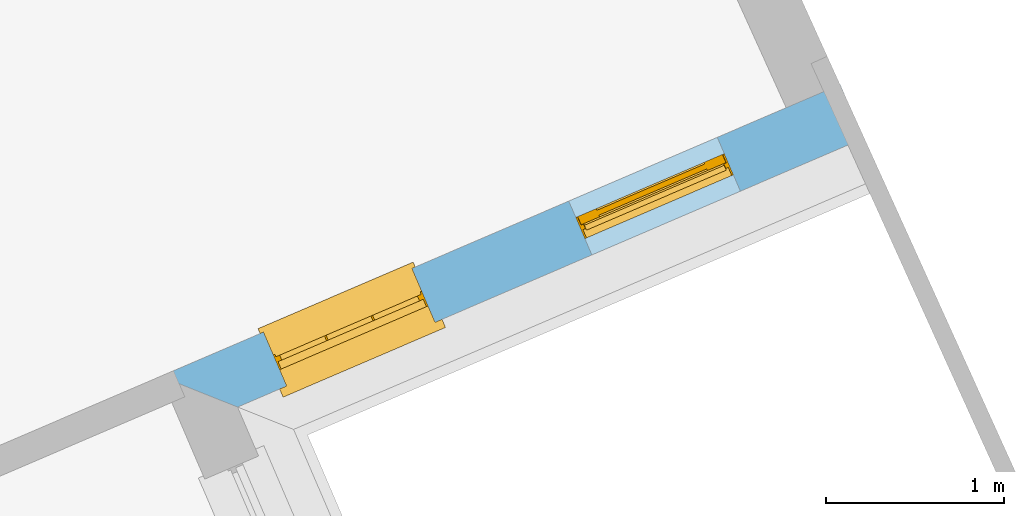
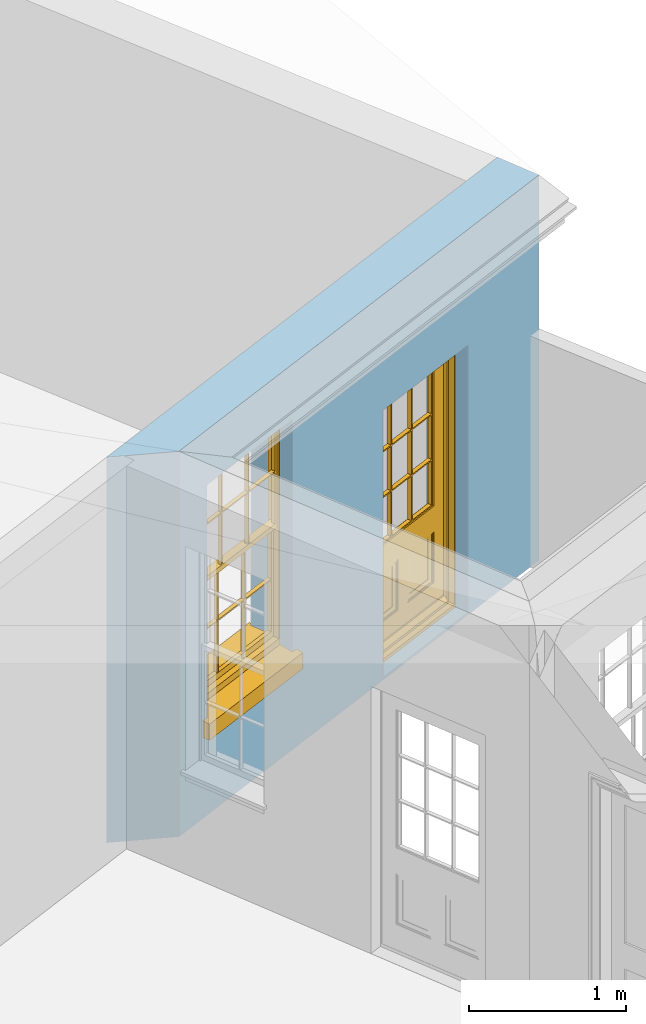
# One storey, part 13 of 19: 1 door, 1 window, 2 openings, plus 1 element that does not belong to this part.
"""IFC2X3 building model written with IfcOpenShell, lengths in metres."""

import ifcopenshell
import ifcopenshell.guid

model = None  # the IFC model being written
_history = None  # IfcOwnerHistory: only IFC2X3 demands one
_inside = {}  # id of a spatial element -> (the spatial element, [elements in it])
_under = {}  # id of a project, library or spatial element -> (it, [spatial elements below it])
_declared = {}  # id of a project -> (the project, [libraries it declares])
_typed = {}  # id of a type object -> (the type object, [elements of that type])
_made_of = {}  # id of a material, layer set ... -> (it, [elements and type objects made of it])


def new_model(schema):
    """Start an empty IFC model of exactly this schema.

    Asked for "IFC4X3", IfcOpenShell would pick the latest addendum, in which some entities
    have other attributes; the version numbers below select the first issue.
    IFC2X3 requires an IfcOwnerHistory on every rooted entity: one is made here for all.
    """
    global model, _history
    if schema == "IFC4X3":
        model = ifcopenshell.file(schema_version=(4, 3, 0, 0))
    else:
        model = ifcopenshell.file(schema=schema)
    _inside.clear()
    _under.clear()
    _declared.clear()
    _typed.clear()
    _made_of.clear()
    _history = None
    if model.schema == "IFC2X3":
        org = make("IfcOrganization", Name="unknown")
        user = make(
            "IfcPersonAndOrganization",
            ThePerson=make("IfcPerson", FamilyName="unknown"),
            TheOrganization=org,
        )
        app = make(
            "IfcApplication",
            ApplicationDeveloper=org,
            Version="unknown",
            ApplicationFullName="unknown",
            ApplicationIdentifier="unknown",
        )
        _history = make(
            "IfcOwnerHistory",
            OwningUser=user,
            OwningApplication=app,
            ChangeAction="ADDED",
            CreationDate=0,
        )
    return model


def make(cls, **values):
    """One entity of the class cls with the attributes given. An attribute that is None is left unset."""
    return model.create_entity(
        cls, **{name: value for name, value in values.items() if value is not None}
    )


def rooted(cls, **values):
    """An entity with a GlobalId (a new one), such as an element, a storey or a relation."""
    return make(cls, GlobalId=ifcopenshell.guid.new(), OwnerHistory=_history, **values)


def si_unit(unit_type, name, prefix=None):
    """IfcSIUnit, for example si_unit("LENGTHUNIT", "METRE", prefix="MILLI")."""
    return make("IfcSIUnit", UnitType=unit_type, Prefix=prefix, Name=name)


def assignment(units):
    """IfcUnitAssignment: the units of a project."""
    return None if units is None else make("IfcUnitAssignment", Units=units)


def point(xyz):
    """IfcCartesianPoint."""
    return None if xyz is None else make("IfcCartesianPoint", Coordinates=xyz)


def direction(xyz):
    """IfcDirection."""
    return None if xyz is None else make("IfcDirection", DirectionRatios=xyz)


def frame(location, z_axis=None, x_axis=None):
    """IfcAxis2Placement3D, a coordinate frame: its origin and axes. An axis left out is left unset."""
    return make(
        "IfcAxis2Placement3D",
        Location=point(location),
        Axis=direction(z_axis),
        RefDirection=direction(x_axis),
    )


def origin():
    """The frame at (0, 0, 0) with its axes left unset."""
    return frame((0.0, 0.0, 0.0))


def place(relative_to, where):
    """IfcLocalPlacement: puts the frame where relative to a parent placement (None: the world)."""
    return make(
        "IfcLocalPlacement", PlacementRelTo=relative_to, RelativePlacement=where
    )


def context(
    kind, dimensions, precision=None, world=None, true_north=None, identifier=None
):
    """IfcGeometricRepresentationContext, for example the 3D "Model" context."""
    return make(
        "IfcGeometricRepresentationContext",
        ContextIdentifier=identifier,
        ContextType=kind,
        CoordinateSpaceDimension=dimensions,
        Precision=precision,
        WorldCoordinateSystem=world,
        TrueNorth=true_north,
    )


def subcontext(parent, identifier, kind, view, scale=None):
    """IfcGeometricRepresentationSubContext, for example "Body" below "Model"."""
    return make(
        "IfcGeometricRepresentationSubContext",
        ContextIdentifier=identifier,
        ContextType=kind,
        ParentContext=parent,
        TargetScale=scale,
        TargetView=view,
    )


def project(units=None, contexts=None):
    """IfcProject with its units and contexts."""
    return rooted(
        "IfcProject",
        Name="project",
        RepresentationContexts=contexts,
        UnitsInContext=assignment(units),
    )


def spatial(cls, under=None, at=None, **own):
    """A site, building, storey or space (cls), placed at a placement, below another one or the project."""
    s = rooted(cls, ObjectPlacement=at, **own)
    if under is not None:
        _under.setdefault(under.id(), (under, []))[1].append(s)
    return s


def polyline(points):
    """IfcPolyline through the points."""
    return make("IfcPolyline", Points=[point(p) for p in points])


def outline(outer, holes=None, kind="AREA"):
    """IfcArbitraryClosedProfileDef: a profile drawn as a closed curve; with holes, ...WithVoids."""
    if holes is None:
        return make("IfcArbitraryClosedProfileDef", ProfileType=kind, OuterCurve=outer)
    return make(
        "IfcArbitraryProfileDefWithVoids",
        ProfileType=kind,
        OuterCurve=outer,
        InnerCurves=holes,
    )


def extrude(swept, where, along, depth):
    """IfcExtrudedAreaSolid: the profile swept, set in the frame where, extruded along a direction by depth."""
    return make(
        "IfcExtrudedAreaSolid",
        SweptArea=swept,
        Position=where,
        ExtrudedDirection=direction(along),
        Depth=depth,
    )


def faces_of(points, faces, orient=None, outer=None):
    """IfcFace entities. A face is a list of loops; a loop is a list of indices into points, from 0.

    orient and outer hold one flag for each loop. By default every Orientation is true, the
    first loop of a face is its IfcFaceOuterBound and the others are IfcFaceBound.
    """
    made = []
    for i, loops in enumerate(faces):
        bounds = []
        for j, loop in enumerate(loops):
            is_outer = j == 0 if outer is None else outer[i][j]
            bounds.append(
                make(
                    "IfcFaceOuterBound" if is_outer else "IfcFaceBound",
                    Bound=make("IfcPolyLoop", Polygon=[points[k] for k in loop]),
                    Orientation=True if orient is None else orient[i][j],
                )
            )
        made.append(make("IfcFace", Bounds=bounds))
    return made


def faceted_brep(points, faces, orient=None, outer=None, voids=None):
    """IfcFacetedBrep: a solid bounded by flat faces; with voids (closed shells), ...WithVoids."""
    shared = [point(p) for p in points]
    hull = make("IfcClosedShell", CfsFaces=faces_of(shared, faces, orient, outer))
    if voids is None:
        return make("IfcFacetedBrep", Outer=hull)
    return make(
        "IfcFacetedBrepWithVoids",
        Outer=hull,
        Voids=[
            make(cls, CfsFaces=faces_of(shared, fs, o, b)) for cls, fs, o, b in voids
        ],
    )


def shape(context_of_items, identifier, shape_type, items):
    """IfcShapeRepresentation: the items that make up one representation, for example the "Body"."""
    return make(
        "IfcShapeRepresentation",
        ContextOfItems=context_of_items,
        RepresentationIdentifier=identifier,
        RepresentationType=shape_type,
        Items=items,
    )


def material(Name=None, Category=None):
    """IfcMaterial."""
    return make("IfcMaterial", Name=Name, Category=Category)


def layer(
    of_material, thickness, ventilated=None, Name=None, Category=None, Priority=None
):
    """IfcMaterialLayer: one layer of a wall or slab, of a material (None: an air gap)."""
    return make(
        "IfcMaterialLayer",
        Material=of_material,
        LayerThickness=thickness,
        IsVentilated=ventilated,
        Name=Name,
        Category=Category,
        Priority=Priority,
    )


def layer_set(layers, Name=None):
    """IfcMaterialLayerSet."""
    return make("IfcMaterialLayerSet", MaterialLayers=layers, LayerSetName=Name)


def layer_usage(for_layer_set, set_direction, sense, offset, extent=None):
    """IfcMaterialLayerSetUsage: how a layer set lies in its element."""
    return make(
        "IfcMaterialLayerSetUsage",
        ForLayerSet=for_layer_set,
        LayerSetDirection=set_direction,
        DirectionSense=sense,
        OffsetFromReferenceLine=offset,
        ReferenceExtent=extent,
    )


def made_of(thing, what):
    """Note that an element or type object is made of a material, layer set ...; save() writes the relation."""
    if what is not None:
        _made_of.setdefault(what.id(), (what, []))[1].append(thing)
    return thing


def element(
    cls,
    number,
    at=None,
    inside=None,
    cuts=None,
    type_object=None,
    material=None,
    context=None,
    identifier="Body",
    shape_type=None,
    held_by="IfcProductDefinitionShape",
    body=None,
    shapes=None,
    **own,
):
    """One element of the class cls, such as IfcWall. Its Tag is "e" and its number.

    at: its placement. inside: the storey or other place that contains it. cuts: it is an
    opening in that element (IfcRelVoidsElement). A single representation is given by context,
    identifier, shape_type and body (its items); several are given by shapes. held_by: the class
    of the entity that holds the representations. save() writes the other relations.
    """
    e = rooted(cls, Tag="e%d" % number, ObjectPlacement=at, **own)
    if body is not None:
        shapes = [shape(context, identifier, shape_type, body)]
    if shapes is not None:
        e.Representation = make(held_by, Representations=shapes)
    if inside is not None:
        _inside.setdefault(inside.id(), (inside, []))[1].append(e)
    if cuts is not None:
        rooted(
            "IfcRelVoidsElement", RelatingBuildingElement=cuts, RelatedOpeningElement=e
        )
    if type_object is not None:
        _typed.setdefault(type_object.id(), (type_object, []))[1].append(e)
    return made_of(e, material)


def fill(opening, filler):
    """IfcRelFillsElement: the door or window that sits in an opening."""
    return rooted(
        "IfcRelFillsElement",
        RelatingOpeningElement=opening,
        RelatedBuildingElement=filler,
    )


def aggregate(whole, parts):
    """IfcRelAggregates: a whole, such as a stair, and the parts it consists of."""
    return rooted("IfcRelAggregates", RelatingObject=whole, RelatedObjects=parts)


def save(model, path):
    """Write the relations noted so far, then the file.

    IfcRelAggregates (storeys below a building ...), IfcRelContainedInSpatialStructure (elements
    in a storey), IfcRelDefinesByType, IfcRelAssociatesMaterial and IfcRelDeclares: one each for
    every whole, place, type object, material and project.
    """
    for whole, parts in _under.values():
        aggregate(whole, parts)
    for where, things in _inside.values():
        rooted(
            "IfcRelContainedInSpatialStructure",
            RelatedElements=things,
            RelatingStructure=where,
        )
    for kind, things in _typed.values():
        rooted("IfcRelDefinesByType", RelatedObjects=things, RelatingType=kind)
    for what, things in _made_of.values():
        rooted("IfcRelAssociatesMaterial", RelatedObjects=things, RelatingMaterial=what)
    for by, libraries in _declared.values():
        rooted("IfcRelDeclares", RelatingContext=by, RelatedDefinitions=libraries)
    model.write(path)


model = new_model("IFC2X3")

# Units and contexts
model_context = context("Model", 3, world=origin())
body_context = subcontext(model_context, "Body", "Model", "MODEL_VIEW")
ifc_project = project(units=[si_unit("PLANEANGLEUNIT", "RADIAN"), si_unit("MASSUNIT", "GRAM", prefix="KILO"), si_unit("FORCEUNIT", "NEWTON", prefix="KILO"), si_unit("LENGTHUNIT", "METRE")], contexts=[model_context])

# Site, building, storey
site_placement = place(None, origin())
site = spatial("IfcSite", under=ifc_project, at=site_placement, CompositionType="ELEMENT")
building_placement = place(None, origin())
building = spatial("IfcBuilding", under=site, at=building_placement, Name="Building plot-0", CompositionType="ELEMENT")
storey_placement = place(None, origin())
storey = spatial("IfcBuildingStorey", under=building, at=storey_placement, Name="Floor 0", CompositionType="ELEMENT", Elevation=0.0)

# Wall, openings, window, door
ifc_material = material(Name="Masonry")
ifc_layer = layer(ifc_material, 0.33, ventilated=False)
ifc_layer_set = layer_set([ifc_layer], Name="My Wall")
ifc_layer_usage = layer_usage(ifc_layer_set, "AXIS2", "NEGATIVE", 0.08)
wall_placement = place(storey_placement, origin())
wall = element("IfcWallStandardCase", 1, at=wall_placement, inside=storey, material=ifc_layer_usage, Name="exterior", context=body_context, shape_type="SweptSolid", body=[
    extrude(outline(polyline([(20.2669562981244, 33.0257829198726), (20.7003749450695, 32.8527272164698), (24.2232689108841, 34.3651259555113), (24.0930874391129, 34.6683631306853), (20.2669562981244, 33.0257829198726)])), origin(), (0.0, 0.0, 1.0), 3.0),
])
opening_1_placement = place(storey_placement, frame((0.0, 0.0, 0.75)))
opening_1 = element("IfcOpeningElement", 2, at=opening_1_placement, cuts=wall, Name="Opening", ObjectType="Opening", context=body_context, shape_type="SweptSolid", body=[
    extrude(outline(polyline([(20.9760451043186, 32.9710740089891), (21.8122445873741, 33.3300592796309), (21.6820631156029, 33.6332964548049), (20.8458636325474, 33.2743111841631), (20.9760451043186, 32.9710740089891)])), origin(), (0.0, 0.0, 1.0), 1.82),
])
opening_2_placement = place(storey_placement, frame((0.0, 0.0, 0.02)))
opening_2 = element("IfcOpeningElement", 3, at=opening_2_placement, cuts=wall, Name="Opening", ObjectType="Opening", context=body_context, shape_type="SweptSolid", body=[
    extrude(outline(polyline([(22.6947205451952, 33.7089113083307), (23.5309200282507, 34.0678965789725), (23.4007385564795, 34.3711337541464), (22.564539073424, 34.0121484835047), (22.6947205451952, 33.7089113083307)])), origin(), (0.0, 0.0, 1.0), 2.08),
])
window_placement = place(storey_placement, frame((20.8774227772192, 33.2007991416967, 0.75), z_axis=(0.0, 0.0, 1.0), x_axis=(0.836199483055477, 0.358985270641782, 0.0)))
window = element("IfcWindow", 4, at=window_placement, inside=storey, Name="bedroom outside window", OverallHeight=1.82, OverallWidth=0.91, context=body_context, shape_type="Brep", held_by="IfcProductRepresentation", body=[
    faceted_brep([(0.033125, -0.105, 0.975209), (0.01, -0.105, 0.975209), (0.033125, -0.105, 1.376042), (0.876875, -0.105, 0.975209), (0.876875, -0.105, 1.376042), (0.9, -0.105, 0.975209), (0.876875, -0.105, 1.386042), (0.876875, -0.105, 1.786875), (0.9, -0.105, 1.81), (0.033125, -0.105, 1.786875), (0.033125, -0.105, 1.386042), (0.01, -0.105, 1.81), (0.876875, -0.135, 1.376042), (0.876875, -0.135, 0.975209), (0.9, -0.135, 0.937083), (0.033125, -0.135, 1.786875), (0.01, -0.135, 1.81), (0.033125, -0.135, 1.386042), (0.01, -0.135, 0.937083), (0.033125, -0.135, 0.975209), (0.033125, -0.135, 1.376042), (0.876875, -0.135, 1.786875), (0.876875, -0.135, 1.386042), (0.9, -0.135, 1.81), (0.033125, -0.105, 0.937083), (0.01, -0.105, 0.937083), (0.033125, -0.105, 0.53625), (0.876875, -0.105, 0.937083), (0.876875, -0.105, 0.53625), (0.9, -0.105, 0.937083), (0.876875, -0.105, 0.52625), (0.876875, -0.105, 0.125417), (0.9, -0.105, 0.077167), (0.033125, -0.105, 0.125417), (0.033125, -0.105, 0.52625), (0.01, -0.105, 0.077167), (-0.0425, -0.25, 0.01), (-0.0425, -0.3, 0.001667), (0.0, -0.25, 0.01), (0.9525, -0.25, 0.01), (0.91, -0.25, 0.01), (0.9525, -0.3, 0.001667), (-0.02, 0.08, 0.077167), (0.0, 0.08, 0.077167), (-0.02, 0.11, 0.077167), (0.0, -0.06, 0.077167), (0.01, -0.06, 0.077167), (0.91, -0.06, 0.077167), (0.91, 0.08, 0.077167), (0.9, -0.06, 0.077167), (0.93, 0.08, 0.077167), (0.93, 0.11, 0.077167), (0.01, -0.075, 0.975209), (0.9, -0.075, 0.975209), (0.876875, -0.075, 0.125417), (0.876875, -0.075, 0.52625), (0.9, -0.075, 0.077167), (0.876875, -0.075, 0.53625), (0.876875, -0.075, 0.937083), (0.033125, -0.075, 0.125417), (0.01, -0.075, 0.077167), (0.033125, -0.075, 0.52625), (0.033125, -0.075, 0.937083), (0.033125, -0.075, 0.53625), (-0.02, 0.08, 0.052167), (-0.02, 0.11, 0.052167), (0.93, 0.11, 0.052167), (0.93, 0.08, 0.052167), (0.91, 0.08, 0.052167), (0.0, 0.08, 0.052167), (0.91, -0.15, 0.026667), (0.0, -0.15, 0.026667), (-0.0425, -0.3, -0.123333), (0.9525, -0.3, -0.123333), (-0.0425, -0.25, -0.123333), (0.9525, -0.25, -0.123333), (0.01, -0.06, 1.81), (0.9, -0.06, 1.81), (0.0, -0.06, 1.82), (0.91, -0.06, 1.82), (0.01, -0.15, 0.077167), (0.9, -0.15, 0.077167), (0.592292, -0.105, 0.125417), (0.592292, -0.075, 0.125417), (0.317708, -0.075, 0.125417), (0.317708, -0.105, 0.125417), (0.592292, -0.105, 0.53625), (0.317708, -0.105, 0.53625), (0.317708, -0.105, 0.52625), (0.592292, -0.105, 0.52625), (0.592292, -0.075, 0.53625), (0.317708, -0.075, 0.53625), (0.592292, -0.135, 1.386042), (0.592292, -0.105, 1.386042), (0.317708, -0.105, 1.386042), (0.317708, -0.135, 1.386042), (0.317708, -0.135, 1.376042), (0.592292, -0.135, 1.376042), (0.317708, -0.105, 1.376042), (0.592292, -0.105, 1.376042), (0.602292, -0.135, 1.376042), (0.592292, -0.135, 0.975209), (0.602292, -0.135, 0.975209), (0.602292, -0.105, 0.975209), (0.592292, -0.105, 0.975209), (0.602292, -0.105, 1.376042), (0.602292, -0.075, 0.53625), (0.602292, -0.105, 0.53625), (0.317708, -0.075, 0.52625), (0.307708, -0.075, 0.125417), (0.307708, -0.075, 0.52625), (0.602292, -0.075, 0.52625), (0.602292, -0.075, 0.125417), (0.592292, -0.075, 0.52625), (0.307708, -0.075, 0.53625), (0.317708, -0.075, 0.937083), (0.307708, -0.075, 0.937083), (0.602292, -0.075, 0.937083), (0.592292, -0.075, 0.937083), (0.307708, -0.105, 0.52625), (0.307708, -0.105, 0.125417), (0.307708, -0.105, 0.53625), (0.307708, -0.105, 0.937083), (0.592292, -0.105, 0.937083), (0.317708, -0.105, 0.937083), (0.602292, -0.105, 0.937083), (0.602292, -0.105, 0.52625), (0.602292, -0.105, 0.125417), (0.307708, -0.135, 1.386042), (0.307708, -0.135, 1.376042), (0.307708, -0.135, 0.975209), (0.317708, -0.135, 0.975209), (0.317708, -0.135, 1.786875), (0.307708, -0.135, 1.786875), (0.602292, -0.135, 1.786875), (0.592292, -0.135, 1.786875), (0.602292, -0.135, 1.386042), (0.602292, -0.105, 1.386042), (0.307708, -0.105, 1.386042), (0.307708, -0.105, 1.786875), (0.317708, -0.105, 1.786875), (0.592292, -0.105, 1.786875), (0.602292, -0.105, 1.786875), (0.307708, -0.105, 1.376042), (0.317708, -0.105, 0.975209), (0.307708, -0.105, 0.975209), (0.91, -0.15, 1.82), (0.9, -0.15, 1.81), (0.01, -0.15, 1.81), (0.0, -0.15, 1.82), (0.91, -0.25, 0.0), (0.0, -0.25, 0.0), (0.91, 0.08, 0.0), (0.0, 0.08, 0.0)], [[[0, 1, 2]], [[3, 4, 5]], [[6, 7, 8]], [[9, 10, 11]], [[12, 13, 14]], [[15, 16, 17]], [[18, 19, 20]], [[21, 22, 23]], [[24, 25, 26]], [[27, 28, 29]], [[30, 31, 32]], [[33, 34, 35]], [[14, 27, 29]], [[25, 24, 18]], [[36, 37, 38]], [[39, 40, 41]], [[42, 43, 44]], [[45, 46, 43]], [[47, 48, 49]], [[50, 51, 48]], [[1, 0, 52]], [[5, 53, 3]], [[54, 55, 56]], [[57, 58, 53]], [[59, 60, 61]], [[62, 63, 52]], [[48, 43, 46, 49]], [[51, 44, 43, 48]], [[64, 42, 44, 65]], [[65, 44, 51, 66]], [[66, 51, 50, 67]], [[65, 66, 68, 69]], [[60, 56, 49, 46]], [[70, 71, 38, 40]], [[37, 41, 40, 38]], [[37, 72, 73, 41]], [[74, 75, 73, 72]], [[8, 11, 76, 77]], [[76, 78, 79, 77]], [[32, 35, 80, 81]], [[81, 80, 71, 70]], [[82, 83, 84, 85]], [[86, 87, 88, 89]], [[86, 90, 91, 87]], [[92, 93, 94, 95]], [[92, 95, 96, 97]], [[96, 98, 99, 97]], [[100, 97, 101, 102]], [[103, 104, 99, 105]], [[97, 99, 104, 101]], [[102, 103, 105, 100]], [[28, 57, 106, 107]], [[108, 84, 109, 110]], [[111, 112, 83, 113]], [[114, 110, 61, 63]], [[90, 113, 108, 91]], [[115, 91, 114, 116]], [[117, 106, 90, 118]], [[111, 106, 57, 55]], [[119, 110, 109, 120]], [[34, 61, 110, 119]], [[89, 113, 83, 82]], [[88, 108, 113, 89]], [[85, 84, 108, 88]], [[121, 114, 63, 26]], [[122, 116, 114, 121]], [[123, 118, 90, 86]], [[87, 91, 115, 124]], [[107, 106, 117, 125]], [[126, 111, 55, 30]], [[127, 112, 111, 126]], [[126, 30, 28, 107]], [[88, 119, 120, 85]], [[126, 89, 82, 127]], [[125, 123, 86, 107]], [[121, 26, 34, 119]], [[124, 122, 121, 87]], [[128, 17, 20, 129]], [[96, 129, 130, 131]], [[132, 133, 128, 95]], [[134, 135, 92, 136]], [[100, 12, 22, 136]], [[137, 6, 4, 105]], [[94, 138, 139, 140]], [[137, 93, 141, 142]], [[99, 98, 94, 93]], [[143, 2, 10, 138]], [[144, 145, 143, 98]], [[129, 143, 145, 130]], [[20, 2, 143, 129]], [[131, 144, 98, 96]], [[128, 138, 10, 17]], [[133, 139, 138, 128]], [[135, 141, 93, 92]], [[95, 94, 140, 132]], [[22, 6, 137, 136]], [[136, 137, 142, 134]], [[100, 105, 4, 12]], [[107, 86, 89, 126]], [[106, 111, 113, 90]], [[91, 108, 110, 114]], [[87, 121, 119, 88]], [[97, 100, 136, 92]], [[129, 96, 95, 128]], [[98, 143, 138, 94]], [[105, 99, 93, 137]], [[131, 101, 104, 144]], [[124, 115, 118, 123]], [[132, 140, 141, 135]], [[120, 109, 59, 33]], [[15, 9, 139, 133]], [[134, 142, 7, 21]], [[31, 54, 112, 127]], [[36, 74, 72, 37]], [[39, 41, 73, 75]], [[18, 14, 101, 131]], [[23, 16, 132, 135]], [[83, 56, 60, 84]], [[52, 53, 118, 115]], [[53, 52, 144, 104]], [[11, 8, 141, 140]], [[14, 18, 124, 123]], [[2, 1, 11, 10]], [[8, 5, 4, 6]], [[57, 53, 56, 55]], [[60, 52, 63, 61]], [[26, 25, 35, 34]], [[32, 29, 28, 30]], [[14, 23, 22, 12]], [[18, 20, 17, 16]], [[19, 0, 2, 20]], [[17, 10, 9, 15]], [[12, 4, 3, 13]], [[21, 7, 6, 22]], [[27, 58, 57, 28]], [[30, 55, 54, 31]], [[33, 59, 61, 34]], [[26, 63, 62, 24]], [[5, 8, 77, 53]], [[76, 11, 1, 52]], [[46, 45, 78, 76]], [[49, 77, 79, 47]], [[70, 146, 147, 81]], [[71, 80, 148, 149]], [[19, 130, 145, 0]], [[102, 13, 3, 103]], [[116, 122, 24, 62]], [[29, 32, 81, 14]], [[80, 35, 25, 18]], [[60, 46, 76, 52]], [[77, 49, 56, 53]], [[23, 14, 81, 147]], [[16, 148, 80, 18]], [[35, 85, 120]], [[120, 33, 35]], [[127, 82, 32]], [[32, 31, 127]], [[32, 82, 85, 35]], [[102, 101, 14]], [[14, 13, 102]], [[18, 131, 130]], [[130, 19, 18]], [[134, 21, 23]], [[23, 135, 134]], [[16, 15, 133]], [[133, 132, 16]], [[11, 140, 139]], [[139, 9, 11]], [[142, 141, 8]], [[8, 7, 142]], [[23, 147, 148, 16]], [[146, 149, 148, 147]], [[52, 115, 116]], [[116, 62, 52]], [[118, 53, 117]], [[58, 117, 53]], [[27, 125, 117, 58]], [[56, 83, 112]], [[112, 54, 56]], [[109, 84, 60]], [[60, 59, 109]], [[125, 27, 14]], [[14, 123, 125]], [[122, 124, 18]], [[18, 24, 122]], [[145, 144, 52]], [[52, 0, 145]], [[103, 3, 53]], [[53, 104, 103]], [[79, 78, 149, 146]], [[78, 45, 71, 149]], [[146, 70, 47, 79]], [[150, 75, 74, 151]], [[68, 66, 67]], [[48, 68, 67, 50]], [[69, 64, 65]], [[42, 64, 69, 43]], [[69, 68, 152, 153]], [[70, 68, 48, 47]], [[150, 152, 68, 70]], [[43, 69, 71, 45]], [[69, 153, 151, 71]], [[152, 150, 151, 153]], [[38, 151, 74, 36]], [[71, 151, 38]], [[39, 75, 150, 40]], [[40, 150, 70]]]),
])
fill(opening_1, window)
door_placement = place(storey_placement, frame((22.5960982180958, 33.9386364410382, 0.02), z_axis=(0.0, 0.0, 1.0), x_axis=(0.836199483055477, 0.358985270641782, 0.0)))
door = element("IfcDoor", 5, at=door_placement, inside=storey, Name="bedroom outside door", OverallHeight=2.08, OverallWidth=0.91, context=body_context, shape_type="Brep", held_by="IfcProductRepresentation", body=[
    faceted_brep([(0.545, -0.055, 0.265), (0.745, -0.055, 0.265), (0.745, -0.05, 0.265), (0.545, -0.05, 0.265), (0.745, -0.05, 0.58), (0.545, -0.05, 0.58), (0.545, -0.055, 0.58), (0.515, -0.06, 0.235), (0.775, -0.06, 0.235), (0.745, -0.055, 0.58), (0.515, -0.06, 0.61), (0.515, -0.065, 0.235), (0.775, -0.065, 0.235), (0.775, -0.06, 0.61), (0.515, -0.065, 0.61), (0.785, -0.065, 0.225), (0.505, -0.065, 0.225), (0.775, -0.065, 0.61), (0.505, -0.065, 0.62), (0.785, -0.065, 0.62), (0.505, -0.07, 0.225), (0.785, -0.07, 0.225), (0.505, -0.07, 0.62), (0.785, -0.07, 0.62), (0.883, -0.07, 0.075), (0.898, -0.07, 0.075), (0.405, -0.07, 0.62), (0.405, -0.07, 0.225), (0.027, -0.07, 0.075), (0.785, -0.07, 0.82), (0.125, -0.07, 0.82), (0.405, -0.065, 0.62), (0.405, -0.065, 0.225), (0.898, -0.07, 2.068), (0.027, -0.08, 0.075), (0.883, -0.08, 0.075), (0.125, -0.07, 0.225), (0.012, -0.07, 0.075), (0.785, -0.06, 0.82), (0.125, -0.06, 0.82), (0.125, -0.07, 0.62), (0.125, -0.065, 0.62), (0.395, -0.065, 0.61), (0.395, -0.065, 0.235), (0.125, -0.065, 0.225), (0.785, -0.07, 1.895), (0.027, -0.11, 0.045), (0.883, -0.11, 0.045), (0.558333, -0.06, 0.83), (0.351667, -0.06, 0.83), (0.125, -0.07, 1.895), (0.125, -0.06, 1.895), (0.785, -0.06, 1.895), (0.012, -0.07, 2.068), (0.135, -0.065, 0.61), (0.395, -0.06, 0.61), (0.395, -0.06, 0.235), (0.135, -0.065, 0.235), (0.027, -0.11, 0.027), (0.883, -0.11, 0.027), (0.568333, -0.06, 0.83), (0.558333, -0.03, 0.83), (0.351667, -0.03, 0.83), (0.341667, -0.06, 0.83), (0.135, -0.06, 1.185), (0.135, -0.06, 1.53), (0.775, -0.06, 1.53), (0.775, -0.06, 1.185), (0.135, -0.06, 0.61), (0.365, -0.055, 0.58), (0.365, -0.055, 0.265), (0.135, -0.06, 0.235), (0.568333, -0.06, 1.175), (0.558333, -0.06, 1.175), (0.775, -0.06, 0.83), (0.558333, -0.03, 1.175), (0.785, -0.03, 0.82), (0.125, -0.03, 0.82), (0.351667, -0.03, 1.175), (0.351667, -0.06, 1.175), (0.341667, -0.06, 1.175), (0.135, -0.06, 0.83), (0.135, -0.06, 1.175), (0.135, -0.03, 1.185), (0.135, -0.03, 1.53), (0.135, -0.06, 1.54), (0.351667, -0.06, 1.885), (0.558333, -0.06, 1.885), (0.775, -0.03, 1.53), (0.775, -0.03, 1.185), (0.775, -0.06, 1.175), (0.775, -0.06, 1.54), (0.165, -0.055, 0.58), (0.365, -0.05, 0.58), (0.365, -0.05, 0.265), (0.165, -0.055, 0.265), (0.568333, -0.03, 0.83), (0.568333, -0.03, 1.175), (0.568333, -0.06, 1.185), (0.558333, -0.06, 1.185), (0.775, -0.03, 0.83), (0.785, -0.02, 0.82), (0.125, -0.02, 0.82), (0.341667, -0.03, 0.83), (0.341667, -0.03, 1.175), (0.351667, -0.06, 1.185), (0.341667, -0.06, 1.185), (0.135, -0.03, 0.83), (0.341667, -0.03, 1.185), (0.125, -0.03, 1.895), (0.341667, -0.03, 1.53), (0.341667, -0.06, 1.53), (0.135, -0.06, 1.885), (0.341667, -0.06, 1.54), (0.341667, -0.06, 1.885), (0.558333, -0.03, 1.885), (0.351667, -0.03, 1.885), (0.568333, -0.06, 1.885), (0.785, -0.03, 1.895), (0.568333, -0.03, 1.185), (0.568333, -0.06, 1.53), (0.568333, -0.03, 1.53), (0.568333, -0.06, 1.54), (0.775, -0.06, 1.885), (0.165, -0.05, 0.58), (0.165, -0.05, 0.265), (0.775, -0.03, 1.175), (0.558333, -0.06, 1.53), (0.351667, -0.03, 1.185), (0.558333, -0.03, 1.185), (0.505, -0.02, 0.62), (0.405, -0.02, 0.62), (0.125, -0.02, 1.895), (0.785, -0.02, 1.895), (0.351667, -0.06, 1.53), (0.135, -0.03, 1.175), (0.135, -0.03, 1.54), (0.341667, -0.03, 1.54), (0.135, -0.03, 1.885), (0.351667, -0.06, 1.54), (0.558333, -0.03, 1.54), (0.558333, -0.06, 1.54), (0.351667, -0.03, 1.54), (0.775, -0.03, 1.54), (0.568333, -0.03, 1.54), (0.775, -0.03, 1.885), (0.558333, -0.03, 1.53), (0.405, -0.02, 0.225), (0.505, -0.02, 0.225), (0.125, -0.02, 0.62), (0.785, -0.02, 0.62), (0.012, -0.02, 2.068), (0.898, -0.02, 2.068), (0.351667, -0.03, 1.53), (0.341667, -0.03, 1.885), (0.568333, -0.03, 1.885), (0.405, -0.025, 0.225), (0.405, -0.025, 0.62), (0.505, -0.025, 0.62), (0.505, -0.025, 0.225), (0.898, -0.02, 0.027), (0.012, -0.02, 0.027), (0.125, -0.025, 0.62), (0.785, -0.025, 0.62), (0.395, -0.025, 0.235), (0.395, -0.025, 0.61), (0.125, -0.02, 0.225), (0.125, -0.025, 0.225), (0.515, -0.025, 0.61), (0.515, -0.025, 0.235), (0.785, -0.02, 0.225), (0.785, -0.025, 0.225), (0.135, -0.025, 0.61), (0.775, -0.025, 0.61), (0.135, -0.025, 0.235), (0.395, -0.03, 0.235), (0.395, -0.03, 0.61), (0.515, -0.03, 0.61), (0.515, -0.03, 0.235), (0.775, -0.025, 0.235), (0.135, -0.03, 0.61), (0.775, -0.03, 0.61), (0.135, -0.03, 0.235), (0.365, -0.035, 0.265), (0.365, -0.035, 0.58), (0.545, -0.035, 0.58), (0.545, -0.035, 0.265), (0.775, -0.03, 0.235), (0.165, -0.035, 0.58), (0.745, -0.035, 0.58), (0.165, -0.035, 0.265), (0.365, -0.04, 0.58), (0.365, -0.04, 0.265), (0.545, -0.04, 0.58), (0.545, -0.04, 0.265), (0.745, -0.035, 0.265), (0.165, -0.04, 0.58), (0.745, -0.04, 0.58), (0.165, -0.04, 0.265), (0.745, -0.04, 0.265), (0.885, -0.072, 0.025), (0.025, -0.072, 0.025), (0.025, -0.1, 0.025), (0.885, -0.1, 0.025), (0.9, -0.02, 0.025), (0.01, -0.02, 0.025), (0.9, -0.072, 0.025), (0.91, -0.02, 0.0), (0.0, -0.02, 0.0), (0.01, -0.072, 0.025), (0.9, -0.072, 2.07), (0.9, -0.02, 2.07), (0.885, -0.072, 2.055), (0.91, -0.02, 2.08), (0.01, -0.02, 2.07), (0.0, -0.02, 2.08), (0.01, -0.072, 2.07), (0.025, -0.072, 2.055), (0.0, -0.15, 2.08), (0.91, -0.15, 2.08), (0.01, -0.15, 2.07), (0.9, -0.15, 2.07), (0.01, -0.1, 2.07), (0.9, -0.1, 2.07), (0.0, -0.15, 0.0), (0.91, -0.15, 0.0), (0.01, -0.15, 0.025), (0.9, -0.15, 0.025), (0.01, -0.1, 0.025), (0.025, -0.1, 2.055), (0.9, -0.1, 0.025), (0.885, -0.1, 2.055), (0.898, -0.07, 0.027), (0.012, -0.07, 0.027), (0.883, -0.07, 0.027), (0.027, -0.07, 0.027)], [[[0, 1, 2, 3]], [[2, 4, 5, 3]], [[0, 3, 5, 6]], [[1, 0, 7, 8]], [[9, 4, 2, 1]], [[9, 6, 5, 4]], [[0, 6, 10, 7]], [[8, 7, 11, 12]], [[8, 13, 9, 1]], [[13, 10, 6, 9]], [[7, 10, 14, 11]], [[15, 12, 11, 16]], [[12, 17, 13, 8]], [[17, 14, 10, 13]], [[18, 16, 11, 14]], [[15, 19, 17, 12]], [[15, 16, 20, 21]], [[14, 17, 19, 18]], [[16, 18, 22, 20]], [[21, 23, 19, 15]], [[24, 25, 21, 20]], [[23, 22, 18, 19]], [[20, 22, 26, 27]], [[23, 21, 25]], [[28, 24, 20, 27]], [[22, 23, 29]], [[29, 30, 26, 22]], [[27, 26, 31, 32]], [[23, 25, 33, 29]], [[34, 35, 24, 28]], [[28, 27, 36, 37]], [[38, 39, 30, 29]], [[26, 30, 40]], [[26, 40, 41, 31]], [[42, 43, 32, 31]], [[32, 44, 36, 27]], [[33, 45, 29]], [[46, 47, 35, 34]], [[36, 40, 37]], [[39, 38, 48, 49]], [[50, 30, 39, 51]], [[29, 45, 52, 38]], [[53, 37, 40, 30]], [[44, 41, 40, 36]], [[31, 41, 54, 42]], [[43, 42, 55, 56]], [[57, 44, 32, 43]], [[50, 45, 33, 53]], [[47, 46, 58, 59]], [[60, 48, 38]], [[49, 48, 61, 62]], [[49, 63, 39]], [[50, 53, 30]], [[51, 39, 64, 65]], [[45, 50, 51, 52]], [[66, 67, 38, 52]], [[57, 54, 41, 44]], [[42, 54, 68, 55]], [[56, 55, 69, 70]], [[56, 71, 57, 43]], [[60, 72, 73, 48]], [[60, 38, 74]], [[48, 73, 75, 61]], [[76, 77, 62, 61]], [[62, 78, 79, 49]], [[49, 79, 80, 63]], [[63, 81, 39]], [[82, 64, 39]], [[65, 64, 83, 84]], [[85, 51, 65]], [[52, 51, 86, 87]], [[88, 89, 67, 66]], [[90, 38, 67]], [[91, 66, 52]], [[71, 68, 54, 57]], [[55, 68, 92, 69]], [[69, 93, 94, 70]], [[70, 95, 71, 56]], [[96, 97, 72, 60]], [[73, 72, 98, 99]], [[74, 38, 90]], [[100, 96, 60, 74]], [[75, 73, 79, 78]], [[61, 75, 97, 96]], [[101, 102, 77, 76]], [[77, 103, 62]], [[96, 76, 61]], [[103, 104, 78, 62]], [[80, 79, 105, 106]], [[63, 80, 104, 103]], [[81, 63, 103, 107]], [[81, 82, 39]], [[106, 64, 82, 80]], [[106, 108, 83, 64]], [[84, 83, 77, 109]], [[110, 111, 65, 84]], [[112, 51, 85]], [[113, 85, 65, 111]], [[114, 86, 51]], [[115, 87, 86, 116]], [[117, 52, 87]], [[118, 76, 89, 88]], [[119, 98, 67, 89]], [[120, 121, 88, 66]], [[67, 98, 72, 90]], [[91, 122, 120, 66]], [[91, 52, 123]], [[95, 92, 68, 71]], [[69, 92, 124, 93]], [[94, 93, 124, 125]], [[94, 125, 95, 70]], [[72, 97, 126, 90]], [[127, 99, 98, 120]], [[99, 105, 79, 73]], [[74, 90, 126, 100]], [[96, 100, 76]], [[128, 129, 75, 78]], [[97, 75, 129, 119]], [[130, 131, 102, 101]], [[109, 77, 102, 132]], [[133, 101, 76, 118]], [[77, 107, 103]], [[78, 104, 108, 128]], [[111, 106, 105, 134]], [[104, 80, 82, 135]], [[107, 135, 82, 81]], [[110, 108, 106, 111]], [[104, 135, 83, 108]], [[83, 135, 77]], [[136, 84, 109]], [[110, 84, 136, 137]], [[114, 51, 112]], [[85, 136, 138, 112]], [[113, 137, 136, 85]], [[111, 134, 139, 113]], [[86, 114, 113, 139]], [[140, 141, 87, 115]], [[139, 142, 116, 86]], [[109, 118, 115, 116]], [[117, 123, 52]], [[117, 87, 141, 122]], [[126, 89, 76]], [[143, 118, 88]], [[120, 98, 119, 121]], [[119, 89, 126, 97]], [[144, 143, 88, 121]], [[144, 122, 91, 143]], [[127, 120, 122, 141]], [[143, 91, 123, 145]], [[124, 92, 95, 125]], [[146, 129, 99, 127]], [[99, 129, 128, 105]], [[100, 126, 76]], [[121, 119, 129, 146]], [[147, 131, 130, 148]], [[131, 149, 102]], [[130, 101, 150]], [[102, 151, 132]], [[118, 109, 132, 133]], [[101, 133, 152]], [[107, 77, 135]], [[153, 128, 108, 110]], [[134, 105, 128, 153]], [[109, 138, 136]], [[153, 110, 137, 142]], [[154, 114, 112, 138]], [[137, 113, 114, 154]], [[141, 139, 134, 127]], [[141, 140, 142, 139]], [[144, 140, 115, 155]], [[142, 137, 154, 116]], [[155, 115, 118]], [[116, 154, 109]], [[117, 155, 145, 123]], [[122, 144, 155, 117]], [[143, 145, 118]], [[121, 146, 140, 144]], [[146, 127, 134, 153]], [[156, 157, 131, 147]], [[148, 130, 158, 159]], [[148, 160, 161, 147]], [[157, 162, 149, 131]], [[161, 151, 102, 149]], [[101, 152, 160, 150]], [[163, 158, 130, 150]], [[151, 152, 133, 132]], [[154, 138, 109]], [[142, 140, 146, 153]], [[145, 155, 118]], [[157, 156, 164, 165]], [[147, 166, 167, 156]], [[168, 169, 159, 158]], [[170, 148, 159, 171]], [[148, 170, 160]], [[166, 147, 161]], [[172, 162, 157, 165]], [[166, 149, 162, 167]], [[166, 161, 149]], [[150, 160, 170]], [[163, 173, 168, 158]], [[171, 163, 150, 170]], [[174, 164, 156, 167]], [[175, 176, 165, 164]], [[169, 168, 177, 178]], [[171, 159, 169, 179]], [[167, 162, 172, 174]], [[176, 180, 172, 165]], [[179, 173, 163, 171]], [[181, 177, 168, 173]], [[164, 174, 182, 175]], [[183, 184, 176, 175]], [[178, 177, 185, 186]], [[179, 169, 178, 187]], [[174, 172, 180, 182]], [[184, 188, 180, 176]], [[187, 181, 173, 179]], [[189, 185, 177, 181]], [[175, 182, 190, 183]], [[191, 184, 183, 192]], [[185, 193, 194, 186]], [[187, 178, 186, 195]], [[182, 180, 188, 190]], [[191, 196, 188, 184]], [[195, 189, 181, 187]], [[197, 193, 185, 189]], [[183, 190, 198, 192]], [[198, 196, 191, 192]], [[194, 193, 197, 199]], [[195, 186, 194, 199]], [[188, 196, 198, 190]], [[197, 189, 195, 199]], [[200, 201, 202, 203]], [[201, 200, 204, 205]], [[206, 204, 200]], [[204, 207, 208, 205]], [[209, 201, 205]], [[210, 211, 204, 206]], [[206, 200, 212, 210]], [[211, 213, 207, 204]], [[214, 205, 208, 215]], [[216, 217, 201, 209]], [[205, 214, 216, 209]], [[216, 214, 211, 210]], [[210, 212, 217, 216]], [[214, 215, 213, 211]], [[218, 219, 213, 215]], [[219, 218, 220, 221]], [[221, 220, 222, 223]], [[215, 208, 224, 218]], [[225, 224, 208, 207]], [[224, 226, 220, 218]], [[224, 225, 227, 226]], [[219, 225, 207, 213]], [[228, 222, 220, 226]], [[219, 221, 227, 225]], [[226, 227, 203, 202]], [[202, 229, 222, 228]], [[228, 226, 202]], [[227, 221, 223, 230]], [[230, 203, 227]], [[217, 229, 202, 201]], [[231, 223, 222, 229]], [[230, 223, 231, 203]], [[231, 229, 217, 212]], [[212, 200, 203, 231]], [[33, 152, 151, 53]], [[25, 160, 152, 33]], [[161, 37, 53, 151]], [[232, 160, 25]], [[161, 233, 37]], [[160, 232, 234]], [[24, 234, 232, 25]], [[233, 161, 235]], [[37, 233, 235, 28]], [[161, 160, 234, 235]], [[35, 47, 234, 24]], [[28, 235, 46, 34]], [[58, 235, 234, 59]], [[59, 234, 47]], [[58, 46, 235]]]),
])
fill(opening_2, door)

save(model, "model.ifc")
